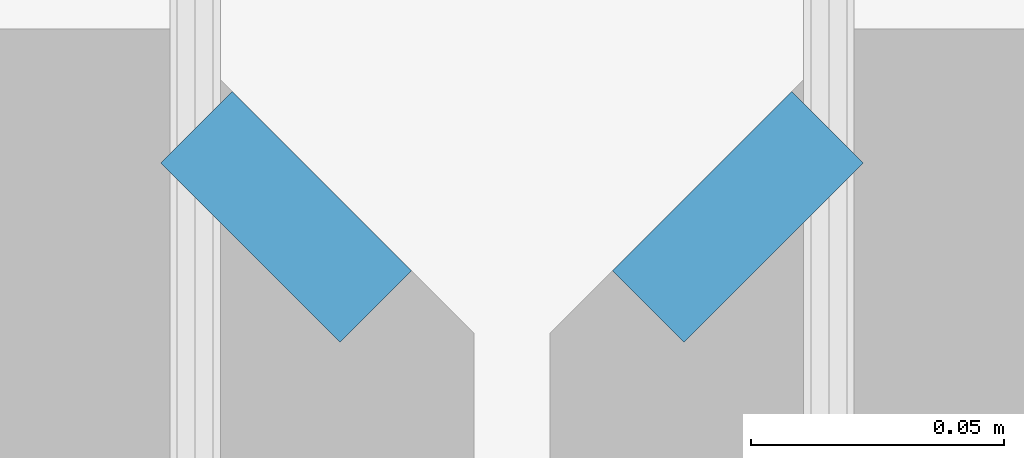
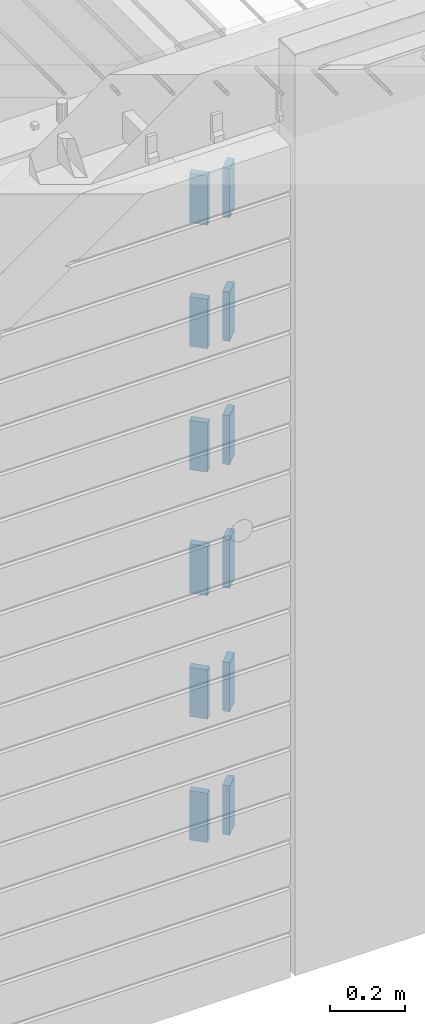
# One storey, part 215 of 350: 12 plates, 14 elements without a shape of their own.
"""IFC2X3 building model written with IfcOpenShell, lengths in millimetres."""

from ifc_helpers import new_model, si_unit, frame, origin_with_axes, place, context, subcontext, project, spatial, faceted_brep, material, type_object, element, aggregate, save


model = new_model("IFC2X3")

# Units and contexts
model_context = context("Model", 3, precision=1e-05, world=origin_with_axes())
body_context = subcontext(model_context, "Body", "Model", "MODEL_VIEW")
ifc_project = project(units=[si_unit("LENGTHUNIT", "METRE", prefix="MILLI"), si_unit("AREAUNIT", "SQUARE_METRE"), si_unit("VOLUMEUNIT", "CUBIC_METRE"), si_unit("MASSUNIT", "GRAM", prefix="KILO"), si_unit("TIMEUNIT", "SECOND"), si_unit("PLANEANGLEUNIT", "RADIAN"), si_unit("SOLIDANGLEUNIT", "STERADIAN"), si_unit("THERMODYNAMICTEMPERATUREUNIT", "DEGREE_CELSIUS"), si_unit("LUMINOUSINTENSITYUNIT", "LUMEN")], contexts=[model_context])

# Site, building, storey
site_placement = place(None, origin_with_axes())
site = spatial("IfcSite", under=ifc_project, at=site_placement, CompositionType="ELEMENT")
building_placement = place(site_placement, origin_with_axes())
building = spatial("IfcBuilding", under=site, at=building_placement, CompositionType="ELEMENT")
storey_placement = place(building_placement, origin_with_axes())
storey = spatial("IfcBuildingStorey", under=building, at=storey_placement, Name="2", CompositionType="ELEMENT", Elevation=0.0)

# Assemblies, plates
assembly_1_placement = place(storey_placement, origin_with_axes())
assembly_1 = element("IfcElementAssembly", 1, at=assembly_1_placement, inside=storey, AssemblyPlace="NOTDEFINED", PredefinedType="REINFORCEMENT_UNIT")
assembly_2_placement = place(assembly_1_placement, origin_with_axes())
assembly_2 = element("IfcElementAssembly", 2, at=assembly_2_placement, Name="Steel Assembly", AssemblyPlace="NOTDEFINED", PredefinedType="RIGID_FRAME")
ifc_material = material(Name="STEEL/Steel_Undefined")
plate_type = type_object("IfcPlateType", PredefinedType="NOTDEFINED")
plate_1_placement = place(assembly_2_placement, frame((28641.4644660941, 7938.1801948466, 87042.5), z_axis=(-0.707106781186547, 0.707106781186548, 0.0), x_axis=(0.707106781186557, 0.707106781186538, 0.0)))
plate_1 = element("IfcPlate", 3, at=plate_1_placement, type_object=plate_type, material=ifc_material, Name="VL_080", context=body_context, shape_type="Brep", body=[
    faceted_brep([(0.0, -80.0, 0.0), (0.0, -80.0, 20.0), (0.0, 80.0, 20.0), (0.0, 80.0, 0.0), (50.0, -80.0, 20.0), (50.0, 80.0, 20.0), (50.0, -80.0, 0.0), (50.0, 80.0, 0.0)], [[[0, 1, 2, 3]], [[1, 4, 5, 2]], [[4, 6, 7, 5]], [[6, 0, 3, 7]], [[5, 7, 3, 2]], [[6, 4, 1, 0]]]),
])
aggregate(assembly_2, [plate_1])
assembly_3_placement = place(assembly_1_placement, origin_with_axes())
assembly_3 = element("IfcElementAssembly", 4, at=assembly_3_placement, Name="Steel Assembly", AssemblyPlace="NOTDEFINED", PredefinedType="RIGID_FRAME")
plate_2_placement = place(assembly_3_placement, frame((28641.4644660941, 7938.1801948466, 86642.5), z_axis=(-0.707106781186547, 0.707106781186548, 0.0), x_axis=(0.707106781186557, 0.707106781186538, 0.0)))
plate_2 = element("IfcPlate", 5, at=plate_2_placement, type_object=plate_type, material=ifc_material, Name="VL_080", context=body_context, shape_type="Brep", body=[
    faceted_brep([(0.0, -80.0, 0.0), (0.0, -80.0, 20.0), (0.0, 80.0, 20.0), (0.0, 80.0, 0.0), (50.0, -80.0, 20.0), (50.0, 80.0, 20.0), (50.0, -80.0, 0.0), (50.0, 80.0, 0.0)], [[[0, 1, 2, 3]], [[1, 4, 5, 2]], [[4, 6, 7, 5]], [[6, 0, 3, 7]], [[5, 7, 3, 2]], [[6, 4, 1, 0]]]),
])
aggregate(assembly_3, [plate_2])
assembly_4_placement = place(assembly_1_placement, origin_with_axes())
assembly_4 = element("IfcElementAssembly", 6, at=assembly_4_placement, Name="Steel Assembly", AssemblyPlace="NOTDEFINED", PredefinedType="RIGID_FRAME")
plate_3_placement = place(assembly_4_placement, frame((28641.4644660941, 7938.1801948466, 86242.5), z_axis=(-0.707106781186547, 0.707106781186548, 0.0), x_axis=(0.707106781186557, 0.707106781186538, 0.0)))
plate_3 = element("IfcPlate", 7, at=plate_3_placement, type_object=plate_type, material=ifc_material, Name="VL_080", context=body_context, shape_type="Brep", body=[
    faceted_brep([(0.0, -80.0, 0.0), (0.0, -80.0, 20.0), (0.0, 80.0, 20.0), (0.0, 80.0, 0.0), (50.0, -80.0, 20.0), (50.0, 80.0, 20.0), (50.0, -80.0, 0.0), (50.0, 80.0, 0.0)], [[[0, 1, 2, 3]], [[1, 4, 5, 2]], [[4, 6, 7, 5]], [[6, 0, 3, 7]], [[5, 7, 3, 2]], [[6, 4, 1, 0]]]),
])
aggregate(assembly_4, [plate_3])

assembly_5_placement = place(storey_placement, origin_with_axes())
assembly_5 = element("IfcElementAssembly", 8, at=assembly_5_placement, inside=storey, AssemblyPlace="NOTDEFINED", PredefinedType="REINFORCEMENT_UNIT")
assembly_6_placement = place(assembly_5_placement, origin_with_axes())
assembly_6 = element("IfcElementAssembly", 9, at=assembly_6_placement, Name="Steel Assembly", AssemblyPlace="NOTDEFINED", PredefinedType="RIGID_FRAME")
plate_4_placement = place(assembly_6_placement, frame((28538.1801948466, 7973.53553390593, 87042.5), z_axis=(0.707106781186557, 0.707106781186538, 0.0), x_axis=(0.707106781186557, -0.707106781186538, 0.0)))
plate_4 = element("IfcPlate", 10, at=plate_4_placement, type_object=plate_type, material=ifc_material, Name="VL_080", context=body_context, shape_type="Brep", body=[
    faceted_brep([(0.0, -80.0, 0.0), (0.0, -80.0, 20.0), (0.0, 80.0, 20.0), (0.0, 80.0, 0.0), (50.0, -80.0, 20.0), (50.0, 80.0, 20.0), (50.0, -80.0, 0.0), (50.0, 80.0, 0.0)], [[[0, 1, 2, 3]], [[1, 4, 5, 2]], [[4, 6, 7, 5]], [[6, 0, 3, 7]], [[5, 7, 3, 2]], [[6, 4, 1, 0]]]),
])
aggregate(assembly_6, [plate_4])
assembly_7_placement = place(assembly_5_placement, origin_with_axes())
assembly_7 = element("IfcElementAssembly", 11, at=assembly_7_placement, Name="Steel Assembly", AssemblyPlace="NOTDEFINED", PredefinedType="RIGID_FRAME")
plate_5_placement = place(assembly_7_placement, frame((28538.1801948466, 7973.53553390593, 86642.5), z_axis=(0.707106781186557, 0.707106781186538, 0.0), x_axis=(0.707106781186557, -0.707106781186538, 0.0)))
plate_5 = element("IfcPlate", 12, at=plate_5_placement, type_object=plate_type, material=ifc_material, Name="VL_080", context=body_context, shape_type="Brep", body=[
    faceted_brep([(0.0, -80.0, 0.0), (0.0, -80.0, 20.0), (0.0, 80.0, 20.0), (0.0, 80.0, 0.0), (50.0, -80.0, 20.0), (50.0, 80.0, 20.0), (50.0, -80.0, 0.0), (50.0, 80.0, 0.0)], [[[0, 1, 2, 3]], [[1, 4, 5, 2]], [[4, 6, 7, 5]], [[6, 0, 3, 7]], [[5, 7, 3, 2]], [[6, 4, 1, 0]]]),
])
aggregate(assembly_7, [plate_5])
assembly_8_placement = place(assembly_5_placement, origin_with_axes())
assembly_8 = element("IfcElementAssembly", 13, at=assembly_8_placement, Name="Steel Assembly", AssemblyPlace="NOTDEFINED", PredefinedType="RIGID_FRAME")
plate_6_placement = place(assembly_8_placement, frame((28538.1801948466, 7973.53553390593, 86242.5), z_axis=(0.707106781186557, 0.707106781186538, 0.0), x_axis=(0.707106781186557, -0.707106781186538, 0.0)))
plate_6 = element("IfcPlate", 14, at=plate_6_placement, type_object=plate_type, material=ifc_material, Name="VL_080", context=body_context, shape_type="Brep", body=[
    faceted_brep([(0.0, -80.0, 0.0), (0.0, -80.0, 20.0), (0.0, 80.0, 20.0), (0.0, 80.0, 0.0), (50.0, -80.0, 20.0), (50.0, 80.0, 20.0), (50.0, -80.0, 0.0), (50.0, 80.0, 0.0)], [[[0, 1, 2, 3]], [[1, 4, 5, 2]], [[4, 6, 7, 5]], [[6, 0, 3, 7]], [[5, 7, 3, 2]], [[6, 4, 1, 0]]]),
])
aggregate(assembly_8, [plate_6])
assembly_9_placement = place(assembly_5_placement, origin_with_axes())
assembly_9 = element("IfcElementAssembly", 15, at=assembly_9_placement, Name="Steel Assembly", AssemblyPlace="NOTDEFINED", PredefinedType="RIGID_FRAME")
plate_7_placement = place(assembly_9_placement, frame((28538.1801948466, 7973.53553390592, 85842.5), z_axis=(0.707106781186557, 0.707106781186538, 0.0), x_axis=(0.707106781186557, -0.707106781186538, 0.0)))
plate_7 = element("IfcPlate", 16, at=plate_7_placement, type_object=plate_type, material=ifc_material, Name="VL_080", context=body_context, shape_type="Brep", body=[
    faceted_brep([(0.0, -80.0, 0.0), (0.0, -80.0, 20.0), (0.0, 80.0, 20.0), (0.0, 80.0, 0.0), (50.0, -80.0, 20.0), (50.0, 80.0, 20.0), (50.0, -80.0, 0.0), (50.0, 80.0, 0.0)], [[[0, 1, 2, 3]], [[1, 4, 5, 2]], [[4, 6, 7, 5]], [[6, 0, 3, 7]], [[5, 7, 3, 2]], [[6, 4, 1, 0]]]),
])
aggregate(assembly_9, [plate_7])
assembly_10_placement = place(assembly_5_placement, origin_with_axes())
assembly_10 = element("IfcElementAssembly", 17, at=assembly_10_placement, Name="Steel Assembly", AssemblyPlace="NOTDEFINED", PredefinedType="RIGID_FRAME")
plate_8_placement = place(assembly_10_placement, frame((28538.1801948466, 7973.53553390591, 85442.5), z_axis=(0.707106781186557, 0.707106781186538, 0.0), x_axis=(0.707106781186557, -0.707106781186538, 0.0)))
plate_8 = element("IfcPlate", 18, at=plate_8_placement, type_object=plate_type, material=ifc_material, Name="VL_080", context=body_context, shape_type="Brep", body=[
    faceted_brep([(0.0, -80.0, 0.0), (0.0, -80.0, 20.0), (0.0, 80.0, 20.0), (0.0, 80.0, 0.0), (50.0, -80.0, 20.0), (50.0, 80.0, 20.0), (50.0, -80.0, 0.0), (50.0, 80.0, 0.0)], [[[0, 1, 2, 3]], [[1, 4, 5, 2]], [[4, 6, 7, 5]], [[6, 0, 3, 7]], [[5, 7, 3, 2]], [[6, 4, 1, 0]]]),
])
aggregate(assembly_10, [plate_8])
assembly_11_placement = place(assembly_5_placement, origin_with_axes())
assembly_11 = element("IfcElementAssembly", 19, at=assembly_11_placement, Name="Steel Assembly", AssemblyPlace="NOTDEFINED", PredefinedType="RIGID_FRAME")
aggregate(assembly_5, [assembly_6, assembly_7, assembly_8, assembly_9, assembly_10, assembly_11])
plate_9_placement = place(assembly_11_placement, frame((28538.1801948466, 7973.53553390592, 85042.5), z_axis=(0.707106781186557, 0.707106781186538, 0.0), x_axis=(0.707106781186557, -0.707106781186538, 0.0)))
plate_9 = element("IfcPlate", 20, at=plate_9_placement, type_object=plate_type, material=ifc_material, Name="VL_080", context=body_context, shape_type="Brep", body=[
    faceted_brep([(0.0, -80.0, 0.0), (0.0, -80.0, 20.0), (0.0, 80.0, 20.0), (0.0, 80.0, 0.0), (50.0, -80.0, 20.0), (50.0, 80.0, 20.0), (50.0, -80.0, 0.0), (50.0, 80.0, 0.0)], [[[0, 1, 2, 3]], [[1, 4, 5, 2]], [[4, 6, 7, 5]], [[6, 0, 3, 7]], [[5, 7, 3, 2]], [[6, 4, 1, 0]]]),
])
aggregate(assembly_11, [plate_9])

# Assembly, plate
assembly_12_placement = place(assembly_1_placement, origin_with_axes())
assembly_12 = element("IfcElementAssembly", 21, at=assembly_12_placement, Name="Steel Assembly", AssemblyPlace="NOTDEFINED", PredefinedType="RIGID_FRAME")
plate_10_placement = place(assembly_12_placement, frame((28641.4644660941, 7938.18019484659, 85842.5), z_axis=(-0.707106781186547, 0.707106781186548, 0.0), x_axis=(0.707106781186557, 0.707106781186538, 0.0)))
plate_10 = element("IfcPlate", 22, at=plate_10_placement, type_object=plate_type, material=ifc_material, Name="VL_080", context=body_context, shape_type="Brep", body=[
    faceted_brep([(0.0, -80.0, 0.0), (0.0, -80.0, 20.0), (0.0, 80.0, 20.0), (0.0, 80.0, 0.0), (50.0, -80.0, 20.0), (50.0, 80.0, 20.0), (50.0, -80.0, 0.0), (50.0, 80.0, 0.0)], [[[0, 1, 2, 3]], [[1, 4, 5, 2]], [[4, 6, 7, 5]], [[6, 0, 3, 7]], [[5, 7, 3, 2]], [[6, 4, 1, 0]]]),
])
aggregate(assembly_12, [plate_10])

assembly_13_placement = place(assembly_1_placement, origin_with_axes())
assembly_13 = element("IfcElementAssembly", 23, at=assembly_13_placement, Name="Steel Assembly", AssemblyPlace="NOTDEFINED", PredefinedType="RIGID_FRAME")
plate_11_placement = place(assembly_13_placement, frame((28641.4644660941, 7938.1801948466, 85442.5), z_axis=(-0.707106781186547, 0.707106781186548, 0.0), x_axis=(0.707106781186557, 0.707106781186538, 0.0)))
plate_11 = element("IfcPlate", 24, at=plate_11_placement, type_object=plate_type, material=ifc_material, Name="VL_080", context=body_context, shape_type="Brep", body=[
    faceted_brep([(0.0, -80.0, 0.0), (0.0, -80.0, 20.0), (0.0, 80.0, 20.0), (0.0, 80.0, 0.0), (50.0, -80.0, 20.0), (50.0, 80.0, 20.0), (50.0, -80.0, 0.0), (50.0, 80.0, 0.0)], [[[0, 1, 2, 3]], [[1, 4, 5, 2]], [[4, 6, 7, 5]], [[6, 0, 3, 7]], [[5, 7, 3, 2]], [[6, 4, 1, 0]]]),
])
aggregate(assembly_13, [plate_11])

# Assembly
assembly_14_placement = place(assembly_1_placement, origin_with_axes())
assembly_14 = element("IfcElementAssembly", 25, at=assembly_14_placement, Name="Steel Assembly", AssemblyPlace="NOTDEFINED", PredefinedType="RIGID_FRAME")

aggregate(assembly_1, [assembly_2, assembly_3, assembly_4, assembly_12, assembly_13, assembly_14])

# Plate
plate_12_placement = place(assembly_14_placement, frame((28641.4644660941, 7938.1801948466, 85042.5), z_axis=(-0.707106781186547, 0.707106781186548, 0.0), x_axis=(0.707106781186557, 0.707106781186538, 0.0)))
plate_12 = element("IfcPlate", 26, at=plate_12_placement, type_object=plate_type, material=ifc_material, Name="VL_080", context=body_context, shape_type="Brep", body=[
    faceted_brep([(0.0, -80.0, 0.0), (0.0, -80.0, 20.0), (0.0, 80.0, 20.0), (0.0, 80.0, 0.0), (50.0, -80.0, 20.0), (50.0, 80.0, 20.0), (50.0, -80.0, 0.0), (50.0, 80.0, 0.0)], [[[0, 1, 2, 3]], [[1, 4, 5, 2]], [[4, 6, 7, 5]], [[6, 0, 3, 7]], [[5, 7, 3, 2]], [[6, 4, 1, 0]]]),
])

aggregate(assembly_14, [plate_12])

save(model, "model.ifc")
